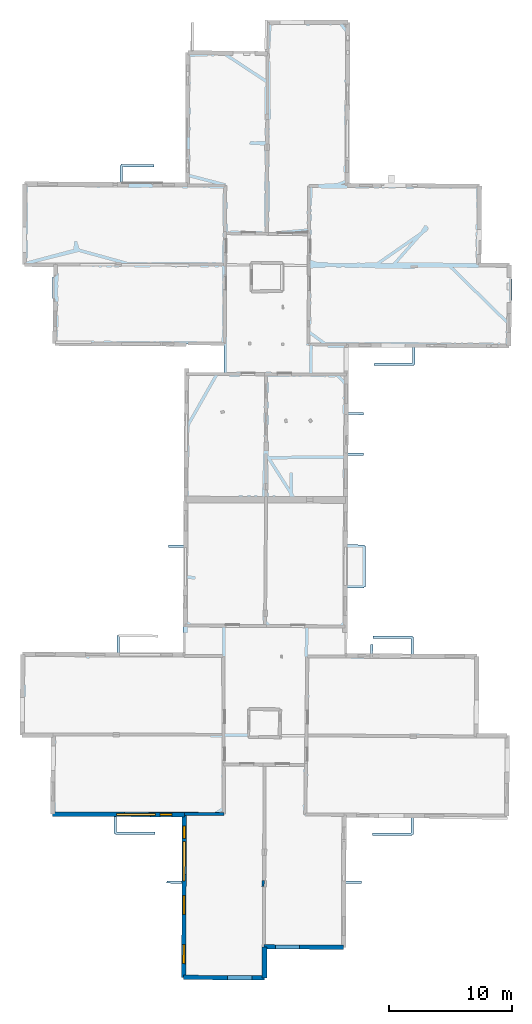
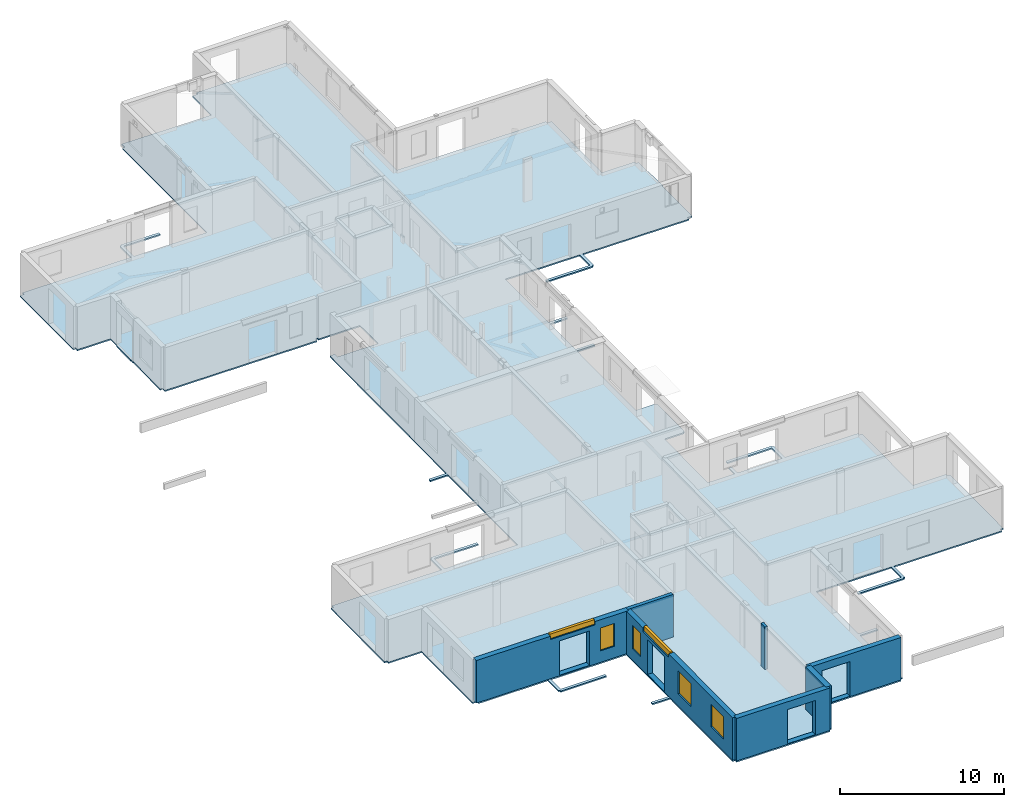
# One storey, part 3 of 17: 7 walls, 6 windows, 1 slab, 10 openings.
"""IFC2X3 building model written with IfcOpenShell, lengths in metres."""

from ifc_helpers import new_model, entity, si_unit, converted_unit, derived_unit, direction, frame, frame_2d, origin, origin_2d_with_axis, place, context, subcontext, project, spatial, polyline, rectangle, outline, extrude, source, transform, mapped, material, layer, layer_set, layer_usage, type_object, type_shapes, element, fill, save


model = new_model("IFC2X3")

# Units and contexts
model_context = context("Model", 3, precision=1e-05, world=origin(), true_north=direction((0.0, 1.0)))
body_context = subcontext(model_context, "Body", "Model", "MODEL_VIEW")
ifc_project = project(units=[si_unit("LENGTHUNIT", "METRE"), si_unit("AREAUNIT", "SQUARE_METRE"), si_unit("VOLUMEUNIT", "CUBIC_METRE"), converted_unit("PLANEANGLEUNIT", "DEGREE", entity("IfcRatioMeasure", 0.0174532925199433), si_unit("PLANEANGLEUNIT", "RADIAN"), dimensions=[0, 0, 0, 0, 0, 0, 0]), si_unit("MASSUNIT", "GRAM", prefix="KILO"), derived_unit("MASSDENSITYUNIT", [(si_unit("MASSUNIT", "GRAM", prefix="KILO"), 1), (si_unit("LENGTHUNIT", "METRE"), -3)]), derived_unit("MOMENTOFINERTIAUNIT", [(si_unit("LENGTHUNIT", "METRE"), 4)]), si_unit("TIMEUNIT", "SECOND"), si_unit("FREQUENCYUNIT", "HERTZ"), si_unit("THERMODYNAMICTEMPERATUREUNIT", "DEGREE_CELSIUS"), derived_unit("THERMALTRANSMITTANCEUNIT", [(si_unit("MASSUNIT", "GRAM", prefix="KILO"), 1), (si_unit("THERMODYNAMICTEMPERATUREUNIT", "KELVIN"), -1), (si_unit("TIMEUNIT", "SECOND"), -3)]), derived_unit("VOLUMETRICFLOWRATEUNIT", [(si_unit("LENGTHUNIT", "METRE"), 3), (si_unit("TIMEUNIT", "SECOND"), -1)]), si_unit("ELECTRICCURRENTUNIT", "AMPERE"), si_unit("ELECTRICVOLTAGEUNIT", "VOLT"), si_unit("POWERUNIT", "WATT"), si_unit("FORCEUNIT", "NEWTON", prefix="KILO"), si_unit("ILLUMINANCEUNIT", "LUX"), si_unit("LUMINOUSFLUXUNIT", "LUMEN"), si_unit("LUMINOUSINTENSITYUNIT", "CANDELA"), derived_unit("USERDEFINED", [(si_unit("MASSUNIT", "GRAM", prefix="KILO"), -1), (si_unit("LENGTHUNIT", "METRE"), -2), (si_unit("TIMEUNIT", "SECOND"), 3), (si_unit("LUMINOUSFLUXUNIT", "LUMEN"), 1)]), derived_unit("LINEARVELOCITYUNIT", [(si_unit("LENGTHUNIT", "METRE"), 1), (si_unit("TIMEUNIT", "SECOND"), -1)]), si_unit("PRESSUREUNIT", "PASCAL"), derived_unit("USERDEFINED", [(si_unit("LENGTHUNIT", "METRE"), -2), (si_unit("MASSUNIT", "GRAM", prefix="KILO"), 1), (si_unit("TIMEUNIT", "SECOND"), -2)]), derived_unit("LINEARFORCEUNIT", [(si_unit("MASSUNIT", "GRAM", prefix="KILO"), 1), (si_unit("LENGTHUNIT", "METRE"), 1), (si_unit("TIMEUNIT", "SECOND"), -2), (si_unit("LENGTHUNIT", "METRE"), -1)]), derived_unit("PLANARFORCEUNIT", [(si_unit("MASSUNIT", "GRAM", prefix="KILO"), 1), (si_unit("LENGTHUNIT", "METRE"), 1), (si_unit("TIMEUNIT", "SECOND"), -2), (si_unit("LENGTHUNIT", "METRE"), -2)])], contexts=[model_context])

# Site, building, storey
placement = place(None, origin())
site = spatial("IfcSite", under=ifc_project, at=placement, CompositionType="ELEMENT")
building = spatial("IfcBuilding", under=site, at=placement, CompositionType="ELEMENT")
storey_placement = place(placement, frame((0.0, 0.0, 5.56662893295288)))
storey = spatial("IfcBuildingStorey", under=building, at=storey_placement, Name="Level 3", CompositionType="ELEMENT", Elevation=5.56662893295288)

# Slab
ifc_material_1 = material(Name="Floor default")
ifc_layer_1 = layer(ifc_material_1, 0.1)
ifc_layer_set_1 = layer_set([ifc_layer_1], Name="Floor : 100mm")
ifc_layer_usage_1 = layer_usage(ifc_layer_set_1, "AXIS3", "POSITIVE", 0.0)
slab_type = type_object("IfcSlabType", Name="Floor : 100mm", PredefinedType="FLOOR")
slab_placement = place(storey_placement, origin())
element("IfcSlab", 1, at=slab_placement, inside=storey, type_object=slab_type, material=ifc_layer_usage_1, Name="Floor : 100mm", ObjectType="Floor : 100mm", PredefinedType="FLOOR", context=body_context, shape_type="SweptSolid", body=[
    extrude(outline(polyline([(-13.6818628311157, 19.4475250244141), (-13.5018672943115, 19.4465522766113), (-13.502082824707, 19.2715530395508), (-11.1656703948975, 19.2686710357666), (-11.2023649215698, 13.0224943161011), (-10.8848142623901, 13.0206289291382), (-10.8853988647461, 12.8360023498535), (-6.02863502502441, 12.820631980896), (-6.03396654129028, 11.4736614227295), (-5.93396759033203, 11.4732656478882), (-5.93354606628418, 11.3732652664185), (-2.70473480224609, 11.386887550354), (-2.70557880401611, 11.5868854522705), (-5.83356904983521, 11.5736885070801), (-5.82863616943359, 12.8199987411499), (-0.508983612060547, 12.8031625747681), (-0.529267311096191, 7.60651683807373), (-1.7634916305542, 7.61934947967529), (-1.76557064056396, 7.41935968399048), (-0.530048370361328, 7.40651369094849), (-0.55985164642334, -0.228813350200653), (-0.384853363037109, -0.229496240615845), (-0.385716438293457, -0.40949422121048), (6.17199993133545, -0.440937221050262), (6.17286205291748, -0.260939657688141), (6.35786151885986, -0.260999798774719), (6.35862064361572, 2.07515239715576), (12.6004419326782, 2.04104065895081), (12.6013975143433, 2.21603798866272), (12.7863988876343, 2.21542882919312), (12.8034410476685, 7.39215517044067), (14.0498266220093, 7.38800001144409), (14.0504922866821, 7.58799934387207), (12.8040990829468, 7.59215450286865), (12.8210649490356, 12.7454996109009), (18.0658988952637, 12.7210683822632), (18.0575714111328, 11.4811639785767), (14.9364957809448, 11.478798866272), (14.9366464614868, 11.2787990570068), (18.156982421875, 11.2812395095825), (18.1569061279297, 11.3812389373779), (18.2569046020508, 11.3805675506592), (18.2658958435059, 12.7201366424561), (25.847526550293, 12.6848201751709), (25.8483657836914, 12.864818572998), (26.0333595275879, 12.8637580871582), (26.0708084106445, 19.3956127166748), (25.8858108520508, 19.3966732025146), (25.8854179382324, 19.5866737365723), (23.5620269775391, 19.5818710327148), (23.6037101745605, 25.833911895752), (23.4187126159668, 25.8351459503174), (23.4195976257324, 26.0251407623291), (18.2884826660156, 26.0490417480469), (18.2887420654297, 27.3966007232666), (18.1887435913086, 27.3966197967529), (18.1892051696777, 27.496618270874), (14.9794225692749, 27.5114345550537), (14.9784994125366, 27.3114376068115), (18.0887222290039, 27.2970809936523), (18.0884780883789, 26.0499725341797), (14.9634351730347, 26.0645294189453), (14.9669637680054, 26.7914867401123), (14.7669668197632, 26.7924575805664), (14.7634382247925, 26.0654621124268), (12.8878049850464, 26.074197769165), (12.9141340255737, 31.3947162628174), (14.2612237930298, 31.3867874145508), (14.2618131637573, 31.4867877960205), (14.3618116378784, 31.486047744751), (14.3863134384155, 34.8014602661133), (14.2863149642944, 34.8022003173828), (14.2868452072144, 34.9021911621094), (12.9315271377563, 34.9093894958496), (12.9508180618286, 38.8077125549316), (12.9673643112183, 42.1514625549316), (14.2157125473022, 42.1465835571289), (14.2164945602417, 42.3465805053711), (12.9683542251587, 42.3514556884766), (12.9837522506714, 45.4631385803223), (14.2194967269897, 45.4615592956543), (14.2197523117065, 45.6615600585938), (12.9847421646118, 45.6631393432617), (13.0004758834839, 48.8428726196289), (13.0108327865601, 50.9355201721191), (18.2085762023926, 50.9096870422363), (18.2024612426758, 49.6521453857422), (15.0865049362183, 49.6663436889648), (15.0855932235718, 49.4663467407227), (18.3015174865723, 49.4516944885254), (18.3019714355469, 49.5516929626465), (18.4019737243652, 49.5512046813965), (18.4085731506348, 50.90869140625), (25.8670806884766, 50.8716201782227), (25.8679504394531, 51.046688079834), (25.8643341064453, 51.0467071533203), (25.8643341064453, 51.0467071533203), (26.2031860351562, 51.0448455810547), (26.2226448059082, 54.5844116210938), (26.2307243347168, 54.584415435791), (26.230655670166, 54.7346115112305), (26.2621078491211, 54.7345809936523), (26.2637023925781, 56.4743232727051), (26.2298583984375, 56.4743537902832), (26.2392768859863, 57.6091766357422), (26.0542793273926, 57.6101951599121), (26.0550727844238, 57.7851905822754), (23.7579460144043, 57.7956008911133), (23.8187217712402, 64.0333938598633), (23.4933433532715, 64.0365600585938), (23.4943161010742, 64.2010192871094), (16.7384986877441, 64.2409057617188), (16.7384986877441, 64.2409057617188), (13.0632944107056, 64.2626037597656), (13.1366453170776, 77.3348617553711), (12.9516496658325, 77.3358993530273), (12.9509763717651, 77.5159072875977), (6.61287021636963, 77.4922180175781), (6.61354160308838, 77.3122253417969), (6.51365566253662, 77.3169784545898), (6.51336574554443, 77.310905456543), (6.22824192047119, 77.3122024536133), (6.21758365631104, 74.9751968383789), (5.41099834442139, 74.9839706420898), (5.41103267669678, 74.9890060424805), (3.61142444610596, 75.0012893676758), (3.61143970489502, 75.0035095214844), (-0.0551462173461914, 75.0433807373047), (-0.0590600967407227, 74.6834030151367), (-0.0588197708129883, 74.6834030151367), (-0.0577459335327148, 74.6539840698242), (-0.227745056152344, 74.6545028686523), (-0.251958847045898, 67.0249328613281), (-0.251153945922852, 67.0249252319336), (-0.259446144104004, 64.3221054077148), (-2.91380214691162, 64.3368682861328), (-2.91378879547119, 64.3415069580078), (-4.84376621246338, 64.3468551635742), (-4.84376430511475, 64.3475799560547), (-5.37471485137939, 64.3505325317383), (-5.3698263168335, 65.6036987304688), (-2.79083919525146, 65.5663833618164), (-2.78794479370117, 65.7663650512695), (-5.46798515319824, 65.8051452636719), (-5.46943187713623, 65.7051544189453), (-5.56943035125732, 65.7055435180664), (-5.57471179962158, 64.3516464233398), (-13.169942855835, 64.3939361572266), (-13.1710252761841, 64.1993637084961), (-13.4671277999878, 64.2000045776367), (-13.481162071228, 57.7265129089355), (-13.3108625411987, 57.7261428833008), (-13.3122816085815, 57.4844398498535), (-10.9715099334717, 57.4706916809082), (-10.9779872894287, 56.6652565002441), (-11.0289754867554, 56.6658897399902), (-11.0508451461792, 54.9061470031738), (-11.0127124786377, 54.9056739807129), (-11.0172395706177, 54.6763000488281), (-10.9988279342651, 54.6759376525879), (-11.0313472747803, 51.3491096496582), (-10.8569431304932, 51.3474044799805), (-10.8582553863525, 51.0671691894531), (-0.181230545043945, 51.0171432495117), (-0.180294036865234, 51.2171287536621), (-0.0211009979248047, 51.2180633544922), (-0.0217456817626953, 51.1178207397461), (2.87568378448486, 51.099178314209), (2.87681293487549, 48.8916053771973), (0.025050163269043, 48.9053268432617), (0.026911735534668, 49.2346420288086), (-0.32308292388916, 49.2366218566895), (-0.404175758361816, 34.893928527832), (-1.64152431488037, 34.8998908996582), (-1.64248847961426, 34.699893951416), (-0.405306816101074, 34.6939315795898), (-0.453645706176758, 26.144359588623), (-5.59138965606689, 26.164945602417), (-5.58574295043945, 27.4251842498779), (-2.48453617095947, 27.391242980957), (-2.482346534729, 27.5912303924561), (-5.68419599533081, 27.6262722015381), (-5.68529033660889, 27.5262794494629), (-5.78529024124146, 27.5267276763916), (-5.79138803482056, 26.1657485961914), (-13.4656372070312, 26.196496963501), (-13.4663782119751, 26.0114974975586), (-13.646372795105, 26.0124702453613), (-13.6818628311157, 19.4475250244141)])), frame((0.0, 0.0, -0.1), z_axis=(0.0, 0.0, 1.0), x_axis=(1.0, 0.0, 0.0)), (0.0, 0.0, 1.0), 0.1),
])

# Wall
ifc_material_2 = material(Name="Default wall")
ifc_layer_2 = layer(ifc_material_2, 0.25)
ifc_layer_set_2 = layer_set([ifc_layer_2], Name="wall_thickness_0.2500")
ifc_layer_usage_2 = layer_usage(ifc_layer_set_2, "AXIS2", "POSITIVE", -0.125)
wall_type_1 = type_object("IfcWallType", Name="wall_thickness_0.2500", PredefinedType="STANDARD", material=ifc_layer_set_2)
wall_1_placement = place(storey_placement, frame((-0.333010372143216, 13.0521478323354, 0.0), z_axis=(0.0, 0.0, 1.0), x_axis=(0.999999736528214, 0.000725908743199676, 0.0)))
element("IfcWallStandardCase", 2, at=wall_1_placement, inside=storey, type_object=wall_type_1, material=ifc_layer_usage_2, Name="Wall:26", ObjectType="Wall", context=body_context, shape_type="SweptSolid", body=[
    extrude(outline(polyline([(3.20296181190765, -0.125), (3.20296181190765, 0.125), (0.0, 0.125), (0.0, -0.125), (3.20296181190765, -0.125)])), origin(), (0.0, 0.0, 1.0), 3.16489877700806),
])

# Wall, openings, windows
ifc_layer_3 = layer(ifc_material_2, 0.349999994039536)
ifc_layer_set_3 = layer_set([ifc_layer_3], Name="wall_thickness_0.3500")
ifc_layer_usage_3 = layer_usage(ifc_layer_set_3, "AXIS2", "POSITIVE", -0.174999997019768)
wall_type_2 = type_object("IfcWallType", Name="wall_thickness_0.3500", PredefinedType="STANDARD", material=ifc_layer_set_3)
wall_2_placement = place(storey_placement, frame((-0.333009935396924, 13.0521476180738, 0.0), z_axis=(0.0, 0.0, 1.0), x_axis=(-0.00390330407123523, -0.999992382079647, 0.0)))
wall_2 = element("IfcWallStandardCase", 3, at=wall_2_placement, inside=storey, type_object=wall_type_2, material=ifc_layer_usage_3, Name="Wall:75", ObjectType="Wall", context=body_context, shape_type="SweptSolid", body=[
    extrude(outline(polyline([(13.2817450467686, -0.174999997019768), (13.2817450467686, 0.174999997019768), (0.0, 0.174999997019768), (0.0, -0.174999997019768), (13.2817450467686, -0.174999997019768)])), origin(), (0.0, 0.0, 1.0), 3.16489877700806),
])
opening_1_placement = place(wall_2_placement, frame((2.84487316602099, -0.174999997019768, 0.0453710556030273)))
element("IfcOpeningElement", 4, at=opening_1_placement, cuts=wall_2, Name="Opening : 2100 x 2570 : 70", ObjectType="Opening", context=body_context, shape_type="SweptSolid", body=[
    extrude(rectangle(XDim=2.1, YDim=2.57, at=frame_2d((1.285, 1.05), x_axis=(0.0, 1.0))), frame((0.0, 0.0, 0.0), z_axis=(0.0, 1.0, 0.0), x_axis=(0.0, 0.0, 1.0)), (0.0, 0.0, 1.0), 0.349999994039536),
])
opening_2_placement = place(wall_2_placement, frame((6.61329872792107, -0.174999997019768, 0.895370960235596)))
opening_2 = element("IfcOpeningElement", 5, at=opening_2_placement, cuts=wall_2, Name="Opening : 1560 x 1705 : 71", ObjectType="Opening", context=body_context, shape_type="SweptSolid", body=[
    extrude(rectangle(XDim=1.56, YDim=1.705, at=frame_2d((0.8525, 0.78), x_axis=(0.0, 1.0))), frame((0.0, 0.0, 0.0), z_axis=(0.0, 1.0, 0.0), x_axis=(0.0, 0.0, 1.0)), (0.0, 0.0, 1.0), 0.349999994039536),
])
opening_3_placement = place(wall_2_placement, frame((10.6282984242227, -0.174999997019768, 0.900371074676514)))
opening_3 = element("IfcOpeningElement", 6, at=opening_3_placement, cuts=wall_2, Name="Opening : 1545 x 1680 : 72", ObjectType="Opening", context=body_context, shape_type="SweptSolid", body=[
    extrude(rectangle(XDim=1.545, YDim=1.68, at=frame_2d((0.84, 0.7725), x_axis=(0.0, 1.0))), frame((0.0, 0.0, 0.0), z_axis=(0.0, 1.0, 0.0), x_axis=(0.0, 0.0, 1.0)), (0.0, 0.0, 1.0), 0.349999994039536),
])
opening_4_placement = place(wall_2_placement, frame((1.0032987733776, -0.174999997019768, 0.840371131896973)))
opening_4 = element("IfcOpeningElement", 7, at=opening_4_placement, cuts=wall_2, Name="Opening : 990 x 1760 : 73", ObjectType="Opening", context=body_context, shape_type="SweptSolid", body=[
    extrude(rectangle(XDim=0.99, YDim=1.76, at=frame_2d((0.88, 0.495), x_axis=(0.0, 1.0))), frame((0.0, 0.0, 0.0), z_axis=(0.0, 1.0, 0.0), x_axis=(0.0, 0.0, 1.0)), (0.0, 0.0, 1.0), 0.349999994039536),
])
opening_5_placement = place(wall_2_placement, frame((2.26329906407389, -0.174999997019768, 2.8953709602356)))
opening_5 = element("IfcOpeningElement", 8, at=opening_5_placement, cuts=wall_2, Name="Opening : 3185 x 360 : 74", ObjectType="Opening", context=body_context, shape_type="SweptSolid", body=[
    extrude(rectangle(XDim=3.185, YDim=0.36, at=frame_2d((0.18, 1.5925), x_axis=(0.0, 1.0))), frame((0.0, 0.0, 0.0), z_axis=(0.0, 1.0, 0.0), x_axis=(0.0, 0.0, 1.0)), (0.0, 0.0, 1.0), 0.349999994039536),
])
ifc_material_3 = material(Name="Window Default")
window_style_1 = type_object("IfcWindowStyle", Name="Window : 1560 x 1705mm", ConstructionType="NOTDEFINED", OperationType="NOTDEFINED", ParameterTakesPrecedence=False, Sizeable=False, material=ifc_material_3)
shared_shape_1 = source(origin(), body_context, "Body", "SweptSolid", [
    extrude(rectangle(XDim=0.174999997019768, YDim=1.56, at=origin_2d_with_axis()), frame((0.78, 0.174999997019768, 0.0), z_axis=(0.0, 0.0, 1.0), x_axis=(0.0, 1.0, 0.0)), (0.0, 0.0, 1.0), 1.705),
])
type_shapes(window_style_1, [shared_shape_1])
window_1_placement = place(opening_2_placement, origin())
window_1 = element("IfcWindow", 9, at=window_1_placement, inside=storey, type_object=window_style_1, Name="Window : 1560 x 1705mm : 43", ObjectType="Window : 1560 x 1705mm", OverallHeight=1.705, OverallWidth=1.56, context=body_context, shape_type="MappedRepresentation", body=[
    mapped(shared_shape_1, transform((0.0, 0.0, 0.0), scale=1.0)),
])
fill(opening_2, window_1)
window_style_2 = type_object("IfcWindowStyle", Name="Window : 1545 x 1680mm", ConstructionType="NOTDEFINED", OperationType="NOTDEFINED", ParameterTakesPrecedence=False, Sizeable=False, material=ifc_material_3)
shared_shape_2 = source(origin(), body_context, "Body", "SweptSolid", [
    extrude(rectangle(XDim=0.174999997019768, YDim=1.545, at=origin_2d_with_axis()), frame((0.7725, 0.174999997019768, 0.0), z_axis=(0.0, 0.0, 1.0), x_axis=(0.0, 1.0, 0.0)), (0.0, 0.0, 1.0), 1.68),
])
type_shapes(window_style_2, [shared_shape_2])
window_2_placement = place(opening_3_placement, origin())
window_2 = element("IfcWindow", 10, at=window_2_placement, inside=storey, type_object=window_style_2, Name="Window : 1545 x 1680mm : 44", ObjectType="Window : 1545 x 1680mm", OverallHeight=1.68, OverallWidth=1.545, context=body_context, shape_type="MappedRepresentation", body=[
    mapped(shared_shape_2, transform((0.0, 0.0, 0.0), scale=1.0)),
])
fill(opening_3, window_2)
window_style_3 = type_object("IfcWindowStyle", Name="Window : 990 x 1760mm", ConstructionType="NOTDEFINED", OperationType="NOTDEFINED", ParameterTakesPrecedence=False, Sizeable=False, material=ifc_material_3)
shared_shape_3 = source(origin(), body_context, "Body", "SweptSolid", [
    extrude(rectangle(XDim=0.174999997019768, YDim=0.99, at=origin_2d_with_axis()), frame((0.495, 0.174999997019768, 0.0), z_axis=(0.0, 0.0, 1.0), x_axis=(0.0, 1.0, 0.0)), (0.0, 0.0, 1.0), 1.76),
])
type_shapes(window_style_3, [shared_shape_3])
window_3_placement = place(opening_4_placement, origin())
window_3 = element("IfcWindow", 11, at=window_3_placement, inside=storey, type_object=window_style_3, Name="Window : 990 x 1760mm : 45", ObjectType="Window : 990 x 1760mm", OverallHeight=1.76, OverallWidth=0.99, context=body_context, shape_type="MappedRepresentation", body=[
    mapped(shared_shape_3, transform((0.0, 0.0, 0.0), scale=1.0)),
])
fill(opening_4, window_3)
window_style_4 = type_object("IfcWindowStyle", Name="Window : 3185 x 360mm", ConstructionType="NOTDEFINED", OperationType="NOTDEFINED", ParameterTakesPrecedence=False, Sizeable=False, material=ifc_material_3)
shared_shape_4 = source(origin(), body_context, "Body", "SweptSolid", [
    extrude(rectangle(XDim=0.174999997019768, YDim=3.185, at=origin_2d_with_axis()), frame((1.5925, 0.174999997019768, 0.0), z_axis=(0.0, 0.0, 1.0), x_axis=(0.0, 1.0, 0.0)), (0.0, 0.0, 1.0), 0.36),
])
type_shapes(window_style_4, [shared_shape_4])
window_4_placement = place(opening_5_placement, origin())
window_4 = element("IfcWindow", 12, at=window_4_placement, inside=storey, type_object=window_style_4, Name="Window : 3185 x 360mm : 46", ObjectType="Window : 3185 x 360mm", OverallHeight=0.36, OverallWidth=3.185, context=body_context, shape_type="MappedRepresentation", body=[
    mapped(shared_shape_4, transform((0.0, 0.0, 0.0), scale=1.0)),
])
fill(opening_5, window_4)

# Wall, opening
wall_3_placement = place(storey_placement, frame((6.12003023263525, 2.25145893733467, 0.0), z_axis=(0.0, 0.0, 1.0), x_axis=(0.999985067038057, -0.00546495204860505, 0.0)))
wall_3 = element("IfcWallStandardCase", 13, at=wall_3_placement, inside=storey, type_object=wall_type_2, material=ifc_layer_usage_3, Name="Wall:102", ObjectType="Wall", context=body_context, shape_type="SweptSolid", body=[
    extrude(outline(polyline([(6.48146485234835, -0.174999997019768), (6.48146485234835, 0.174999997019768), (0.0, 0.174999997019768), (0.0, -0.174999997019768), (6.48146485234835, -0.174999997019768)])), origin(), (0.0, 0.0, 1.0), 3.16489877700806),
])
opening_6_placement = place(wall_3_placement, frame((0.93442786590217, -0.174999997019768, 0.0303711891174316)))
element("IfcOpeningElement", 14, at=opening_6_placement, cuts=wall_3, Name="Opening : 1955 x 2580 : 95", ObjectType="Opening", context=body_context, shape_type="SweptSolid", body=[
    extrude(rectangle(XDim=1.955, YDim=2.58, at=frame_2d((1.29, 0.9775), x_axis=(0.0, 1.0))), frame((0.0, 0.0, 0.0), z_axis=(0.0, 1.0, 0.0), x_axis=(0.0, 0.0, 1.0)), (0.0, 0.0, 1.0), 0.349999994039536),
])

# Wall
ifc_layer_4 = layer(ifc_material_2, 0.2)
ifc_layer_set_4 = layer_set([ifc_layer_4], Name="wall_thickness_0.2000")
ifc_layer_usage_4 = layer_usage(ifc_layer_set_4, "AXIS2", "POSITIVE", -0.1)
wall_type_3 = type_object("IfcWallType", Name="wall_thickness_0.2000", PredefinedType="STANDARD", material=ifc_layer_set_4)
wall_4_placement = place(storey_placement, frame((6.0573713470562, 7.62690810693301, 0.0), z_axis=(0.0, 0.0, 1.0), x_axis=(-0.0159759962458232, -0.999872375627987, 0.0)))
element("IfcWallStandardCase", 15, at=wall_4_placement, inside=storey, type_object=wall_type_3, material=ifc_layer_usage_4, Name="Wall:107", ObjectType="Wall", context=body_context, shape_type="SweptSolid", body=[
    extrude(outline(polyline([(0.489999841372481, -0.1), (0.489999841372481, 0.1), (0.0, 0.1), (0.0, -0.1), (0.489999841372481, -0.1)])), origin(), (0.0, 0.0, 1.0), 3.16489877700806),
])

# Wall, openings, windows
ifc_layer_5 = layer(ifc_material_2, 0.370000004768372)
ifc_layer_set_5 = layer_set([ifc_layer_5], Name="wall_thickness_0.3700")
ifc_layer_usage_5 = layer_usage(ifc_layer_set_5, "AXIS2", "POSITIVE", -0.185000002384186)
wall_type_4 = type_object("IfcWallType", Name="wall_thickness_0.3700", PredefinedType="STANDARD", material=ifc_layer_set_5)
wall_5_placement = place(storey_placement, frame((-11.0223685317857, 13.0214363013508, 0.0), z_axis=(0.0, 0.0, 1.0), x_axis=(0.999994992103045, -0.00316476994922748, 0.0)))
wall_5 = element("IfcWallStandardCase", 16, at=wall_5_placement, inside=storey, type_object=wall_type_4, material=ifc_layer_usage_5, Name="Wall:58", ObjectType="Wall", context=body_context, shape_type="SweptSolid", body=[
    extrude(outline(polyline([(10.6891609482769, -0.185000002384186), (10.6891609482769, 0.185000002384186), (0.0, 0.185000002384186), (0.0, -0.185000002384186), (10.6891609482769, -0.185000002384186)])), origin(), (0.0, 0.0, 1.0), 3.16489877700806),
])
opening_7_placement = place(wall_5_placement, frame((5.83229031872527, -0.185000002384186, 0.0463714599609375)))
element("IfcOpeningElement", 17, at=opening_7_placement, cuts=wall_5, Name="Opening : 2090 x 2555 : 58", ObjectType="Opening", context=body_context, shape_type="SweptSolid", body=[
    extrude(rectangle(XDim=2.09, YDim=2.555, at=frame_2d((1.2775, 1.045), x_axis=(0.0, 1.0))), frame((0.0, 0.0, 0.0), z_axis=(0.0, 1.0, 0.0), x_axis=(0.0, 0.0, 1.0)), (0.0, 0.0, 1.0), 0.370000004768372),
])
opening_8_placement = place(wall_5_placement, frame((5.19434385319465, -0.185000002384186, 2.91537141799927)))
opening_8 = element("IfcOpeningElement", 18, at=opening_8_placement, cuts=wall_5, Name="Opening : 3130 x 340 : 59", ObjectType="Opening", context=body_context, shape_type="SweptSolid", body=[
    extrude(rectangle(XDim=3.13, YDim=0.34, at=frame_2d((0.17, 1.565), x_axis=(0.0, 1.0))), frame((0.0, 0.0, 0.0), z_axis=(0.0, 1.0, 0.0), x_axis=(0.0, 0.0, 1.0)), (0.0, 0.0, 1.0), 0.370000004768372),
])
opening_9_placement = place(wall_5_placement, frame((8.70948768798967, -0.185000002384186, 0.855370998382568)))
opening_9 = element("IfcOpeningElement", 19, at=opening_9_placement, cuts=wall_5, Name="Opening : 965 x 1700 : 60", ObjectType="Opening", context=body_context, shape_type="SweptSolid", body=[
    extrude(rectangle(XDim=0.965, YDim=1.7, at=frame_2d((0.85, 0.4825), x_axis=(0.0, 1.0))), frame((0.0, 0.0, 0.0), z_axis=(0.0, 1.0, 0.0), x_axis=(0.0, 0.0, 1.0)), (0.0, 0.0, 1.0), 0.370000004768372),
])
window_style_5 = type_object("IfcWindowStyle", Name="Window : 3130 x 340mm", ConstructionType="NOTDEFINED", OperationType="NOTDEFINED", ParameterTakesPrecedence=False, Sizeable=False, material=ifc_material_3)
shared_shape_5 = source(origin(), body_context, "Body", "SweptSolid", [
    extrude(rectangle(XDim=0.185000002384186, YDim=3.13, at=origin_2d_with_axis()), frame((1.565, 0.185000002384186, 0.0), z_axis=(0.0, 0.0, 1.0), x_axis=(0.0, 1.0, 0.0)), (0.0, 0.0, 1.0), 0.34),
])
type_shapes(window_style_5, [shared_shape_5])
window_5_placement = place(opening_8_placement, origin())
window_5 = element("IfcWindow", 20, at=window_5_placement, inside=storey, type_object=window_style_5, Name="Window : 3130 x 340mm : 36", ObjectType="Window : 3130 x 340mm", OverallHeight=0.34, OverallWidth=3.13, context=body_context, shape_type="MappedRepresentation", body=[
    mapped(shared_shape_5, transform((0.0, 0.0, 0.0), scale=1.0)),
])
fill(opening_8, window_5)
window_style_6 = type_object("IfcWindowStyle", Name="Window : 965 x 1700mm", ConstructionType="NOTDEFINED", OperationType="NOTDEFINED", ParameterTakesPrecedence=False, Sizeable=False, material=ifc_material_3)
shared_shape_6 = source(origin(), body_context, "Body", "SweptSolid", [
    extrude(rectangle(XDim=0.185000002384186, YDim=0.965, at=origin_2d_with_axis()), frame((0.4825, 0.185000002384186, 0.0), z_axis=(0.0, 0.0, 1.0), x_axis=(0.0, 1.0, 0.0)), (0.0, 0.0, 1.0), 1.7),
])
type_shapes(window_style_6, [shared_shape_6])
window_6_placement = place(opening_9_placement, origin())
window_6 = element("IfcWindow", 21, at=window_6_placement, inside=storey, type_object=window_style_6, Name="Window : 965 x 1700mm : 37", ObjectType="Window : 965 x 1700mm", OverallHeight=1.7, OverallWidth=0.965, context=body_context, shape_type="MappedRepresentation", body=[
    mapped(shared_shape_6, transform((0.0, 0.0, 0.0), scale=1.0)),
])
fill(opening_9, window_6)

# Wall
wall_6_placement = place(storey_placement, frame((6.1736783483078, 2.25116594054612, 0.0), z_axis=(0.0, 0.0, 1.0), x_axis=(-0.000325344145987955, -0.999999947075592, 0.0)))
element("IfcWallStandardCase", 22, at=wall_6_placement, inside=storey, type_object=wall_type_4, material=ifc_layer_usage_5, Name="Wall:65", ObjectType="Wall", context=body_context, shape_type="SweptSolid", body=[
    extrude(outline(polyline([(2.5121057170963, -0.185000002384186), (2.5121057170963, 0.185000002384186), (0.0, 0.185000002384186), (0.0, -0.185000002384186), (2.5121057170963, -0.185000002384186)])), origin(), (0.0, 0.0, 1.0), 3.16489877700806),
])

# Wall, opening
ifc_layer_6 = layer(ifc_material_2, 0.360000014305115)
ifc_layer_set_6 = layer_set([ifc_layer_6], Name="wall_thickness_0.3600")
ifc_layer_usage_6 = layer_usage(ifc_layer_set_6, "AXIS2", "POSITIVE", -0.180000007152557)
wall_type_5 = type_object("IfcWallType", Name="wall_thickness_0.3600", PredefinedType="STANDARD", material=ifc_layer_set_6)
wall_7_placement = place(storey_placement, frame((-0.38485338415971, -0.229496283132059, 0.0), z_axis=(0.0, 0.0, 1.0), x_axis=(0.999988505098123, -0.00479475459437739, 0.0)))
wall_7 = element("IfcWallStandardCase", 23, at=wall_7_placement, inside=storey, type_object=wall_type_5, material=ifc_layer_usage_6, Name="Wall:93", ObjectType="Wall", context=body_context, shape_type="SweptSolid", body=[
    extrude(outline(polyline([(6.55779127395897, -0.180000007152557), (6.55779127395897, 0.180000007152557), (0.0, 0.180000007152557), (0.0, -0.180000007152557), (6.55779127395897, -0.180000007152557)])), origin(), (0.0, 0.0, 1.0), 3.16489877700806),
])
opening_10_placement = place(wall_7_placement, frame((3.55319436026398, -0.180000007152557, 0.0453710556030273)))
element("IfcOpeningElement", 24, at=opening_10_placement, cuts=wall_7, Name="Opening : 1975 x 2540 : 81", ObjectType="Opening", context=body_context, shape_type="SweptSolid", body=[
    extrude(rectangle(XDim=1.975, YDim=2.54, at=frame_2d((1.27, 0.9875), x_axis=(0.0, 1.0))), frame((0.0, 0.0, 0.0), z_axis=(0.0, 1.0, 0.0), x_axis=(0.0, 0.0, 1.0)), (0.0, 0.0, 1.0), 0.360000014305115),
])

save(model, "model.ifc")
